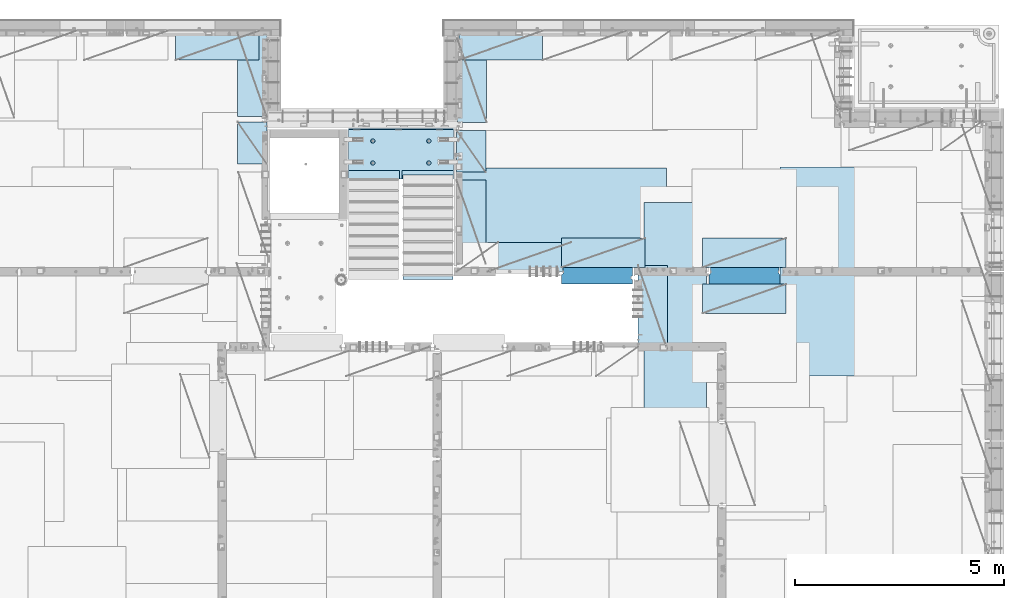
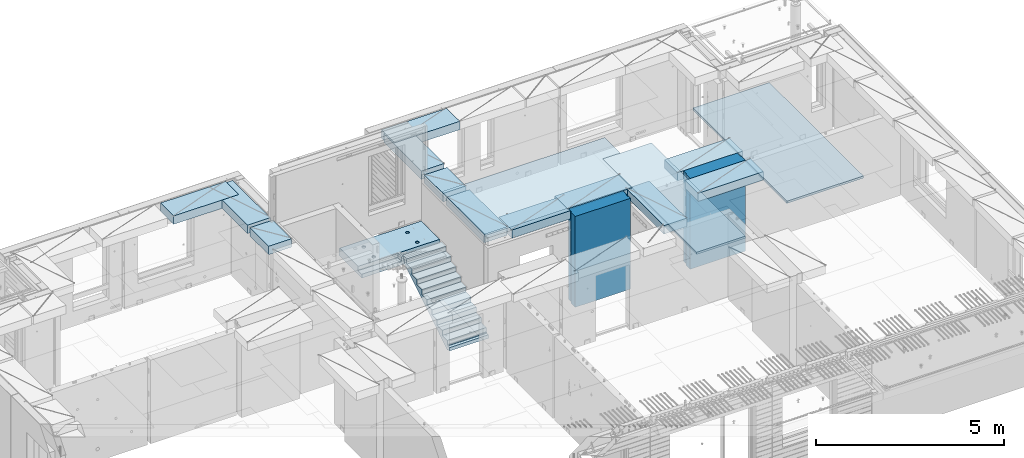
# One storey, part 201 of 341: 18 plates, 1 slab, 19 elements without a shape of their own.
"""IFC2X3 building model written with IfcOpenShell, lengths in millimetres."""

import ifcopenshell
import ifcopenshell.guid

model = None  # the IFC model being written
_history = None  # IfcOwnerHistory: only IFC2X3 demands one
_inside = {}  # id of a spatial element -> (the spatial element, [elements in it])
_under = {}  # id of a project, library or spatial element -> (it, [spatial elements below it])
_declared = {}  # id of a project -> (the project, [libraries it declares])
_typed = {}  # id of a type object -> (the type object, [elements of that type])
_made_of = {}  # id of a material, layer set ... -> (it, [elements and type objects made of it])


def new_model(schema):
    """Start an empty IFC model of exactly this schema.

    Asked for "IFC4X3", IfcOpenShell would pick the latest addendum, in which some entities
    have other attributes; the version numbers below select the first issue.
    IFC2X3 requires an IfcOwnerHistory on every rooted entity: one is made here for all.
    """
    global model, _history
    if schema == "IFC4X3":
        model = ifcopenshell.file(schema_version=(4, 3, 0, 0))
    else:
        model = ifcopenshell.file(schema=schema)
    _inside.clear()
    _under.clear()
    _declared.clear()
    _typed.clear()
    _made_of.clear()
    _history = None
    if model.schema == "IFC2X3":
        org = make("IfcOrganization", Name="unknown")
        user = make(
            "IfcPersonAndOrganization",
            ThePerson=make("IfcPerson", FamilyName="unknown"),
            TheOrganization=org,
        )
        app = make(
            "IfcApplication",
            ApplicationDeveloper=org,
            Version="unknown",
            ApplicationFullName="unknown",
            ApplicationIdentifier="unknown",
        )
        _history = make(
            "IfcOwnerHistory",
            OwningUser=user,
            OwningApplication=app,
            ChangeAction="ADDED",
            CreationDate=0,
        )
    return model


def make(cls, **values):
    """One entity of the class cls with the attributes given. An attribute that is None is left unset."""
    return model.create_entity(
        cls, **{name: value for name, value in values.items() if value is not None}
    )


def rooted(cls, **values):
    """An entity with a GlobalId (a new one), such as an element, a storey or a relation."""
    return make(cls, GlobalId=ifcopenshell.guid.new(), OwnerHistory=_history, **values)


def si_unit(unit_type, name, prefix=None):
    """IfcSIUnit, for example si_unit("LENGTHUNIT", "METRE", prefix="MILLI")."""
    return make("IfcSIUnit", UnitType=unit_type, Prefix=prefix, Name=name)


def assignment(units):
    """IfcUnitAssignment: the units of a project."""
    return None if units is None else make("IfcUnitAssignment", Units=units)


def point(xyz):
    """IfcCartesianPoint."""
    return None if xyz is None else make("IfcCartesianPoint", Coordinates=xyz)


def direction(xyz):
    """IfcDirection."""
    return None if xyz is None else make("IfcDirection", DirectionRatios=xyz)


def frame(location, z_axis=None, x_axis=None):
    """IfcAxis2Placement3D, a coordinate frame: its origin and axes. An axis left out is left unset."""
    return make(
        "IfcAxis2Placement3D",
        Location=point(location),
        Axis=direction(z_axis),
        RefDirection=direction(x_axis),
    )


def origin_with_axes():
    """The frame at (0, 0, 0) with the z axis (0, 0, 1) and the x axis (1, 0, 0) written out."""
    return frame((0.0, 0.0, 0.0), z_axis=(0.0, 0.0, 1.0), x_axis=(1.0, 0.0, 0.0))


def place(relative_to, where):
    """IfcLocalPlacement: puts the frame where relative to a parent placement (None: the world)."""
    return make(
        "IfcLocalPlacement", PlacementRelTo=relative_to, RelativePlacement=where
    )


def context(
    kind, dimensions, precision=None, world=None, true_north=None, identifier=None
):
    """IfcGeometricRepresentationContext, for example the 3D "Model" context."""
    return make(
        "IfcGeometricRepresentationContext",
        ContextIdentifier=identifier,
        ContextType=kind,
        CoordinateSpaceDimension=dimensions,
        Precision=precision,
        WorldCoordinateSystem=world,
        TrueNorth=true_north,
    )


def subcontext(parent, identifier, kind, view, scale=None):
    """IfcGeometricRepresentationSubContext, for example "Body" below "Model"."""
    return make(
        "IfcGeometricRepresentationSubContext",
        ContextIdentifier=identifier,
        ContextType=kind,
        ParentContext=parent,
        TargetScale=scale,
        TargetView=view,
    )


def project(units=None, contexts=None):
    """IfcProject with its units and contexts."""
    return rooted(
        "IfcProject",
        Name="project",
        RepresentationContexts=contexts,
        UnitsInContext=assignment(units),
    )


def spatial(cls, under=None, at=None, **own):
    """A site, building, storey or space (cls), placed at a placement, below another one or the project."""
    s = rooted(cls, ObjectPlacement=at, **own)
    if under is not None:
        _under.setdefault(under.id(), (under, []))[1].append(s)
    return s


def faces_of(points, faces, orient=None, outer=None):
    """IfcFace entities. A face is a list of loops; a loop is a list of indices into points, from 0.

    orient and outer hold one flag for each loop. By default every Orientation is true, the
    first loop of a face is its IfcFaceOuterBound and the others are IfcFaceBound.
    """
    made = []
    for i, loops in enumerate(faces):
        bounds = []
        for j, loop in enumerate(loops):
            is_outer = j == 0 if outer is None else outer[i][j]
            bounds.append(
                make(
                    "IfcFaceOuterBound" if is_outer else "IfcFaceBound",
                    Bound=make("IfcPolyLoop", Polygon=[points[k] for k in loop]),
                    Orientation=True if orient is None else orient[i][j],
                )
            )
        made.append(make("IfcFace", Bounds=bounds))
    return made


def faceted_brep(points, faces, orient=None, outer=None, voids=None):
    """IfcFacetedBrep: a solid bounded by flat faces; with voids (closed shells), ...WithVoids."""
    shared = [point(p) for p in points]
    hull = make("IfcClosedShell", CfsFaces=faces_of(shared, faces, orient, outer))
    if voids is None:
        return make("IfcFacetedBrep", Outer=hull)
    return make(
        "IfcFacetedBrepWithVoids",
        Outer=hull,
        Voids=[
            make(cls, CfsFaces=faces_of(shared, fs, o, b)) for cls, fs, o, b in voids
        ],
    )


def shape(context_of_items, identifier, shape_type, items):
    """IfcShapeRepresentation: the items that make up one representation, for example the "Body"."""
    return make(
        "IfcShapeRepresentation",
        ContextOfItems=context_of_items,
        RepresentationIdentifier=identifier,
        RepresentationType=shape_type,
        Items=items,
    )


def material(Name=None, Category=None):
    """IfcMaterial."""
    return make("IfcMaterial", Name=Name, Category=Category)


def made_of(thing, what):
    """Note that an element or type object is made of a material, layer set ...; save() writes the relation."""
    if what is not None:
        _made_of.setdefault(what.id(), (what, []))[1].append(thing)
    return thing


def type_object(cls, material=None, **own):
    """A type object (cls), such as IfcWallType, which elements share."""
    return made_of(rooted(cls, **own), material)


def element(
    cls,
    number,
    at=None,
    inside=None,
    cuts=None,
    type_object=None,
    material=None,
    context=None,
    identifier="Body",
    shape_type=None,
    held_by="IfcProductDefinitionShape",
    body=None,
    shapes=None,
    **own,
):
    """One element of the class cls, such as IfcWall. Its Tag is "e" and its number.

    at: its placement. inside: the storey or other place that contains it. cuts: it is an
    opening in that element (IfcRelVoidsElement). A single representation is given by context,
    identifier, shape_type and body (its items); several are given by shapes. held_by: the class
    of the entity that holds the representations. save() writes the other relations.
    """
    e = rooted(cls, Tag="e%d" % number, ObjectPlacement=at, **own)
    if body is not None:
        shapes = [shape(context, identifier, shape_type, body)]
    if shapes is not None:
        e.Representation = make(held_by, Representations=shapes)
    if inside is not None:
        _inside.setdefault(inside.id(), (inside, []))[1].append(e)
    if cuts is not None:
        rooted(
            "IfcRelVoidsElement", RelatingBuildingElement=cuts, RelatedOpeningElement=e
        )
    if type_object is not None:
        _typed.setdefault(type_object.id(), (type_object, []))[1].append(e)
    return made_of(e, material)


def aggregate(whole, parts):
    """IfcRelAggregates: a whole, such as a stair, and the parts it consists of."""
    return rooted("IfcRelAggregates", RelatingObject=whole, RelatedObjects=parts)


def save(model, path):
    """Write the relations noted so far, then the file.

    IfcRelAggregates (storeys below a building ...), IfcRelContainedInSpatialStructure (elements
    in a storey), IfcRelDefinesByType, IfcRelAssociatesMaterial and IfcRelDeclares: one each for
    every whole, place, type object, material and project.
    """
    for whole, parts in _under.values():
        aggregate(whole, parts)
    for where, things in _inside.values():
        rooted(
            "IfcRelContainedInSpatialStructure",
            RelatedElements=things,
            RelatingStructure=where,
        )
    for kind, things in _typed.values():
        rooted("IfcRelDefinesByType", RelatedObjects=things, RelatingType=kind)
    for what, things in _made_of.values():
        rooted("IfcRelAssociatesMaterial", RelatedObjects=things, RelatingMaterial=what)
    for by, libraries in _declared.values():
        rooted("IfcRelDeclares", RelatingContext=by, RelatedDefinitions=libraries)
    model.write(path)


model = new_model("IFC2X3")

# Units and contexts
model_context = context("Model", 3, precision=1e-05, world=origin_with_axes())
body_context = subcontext(model_context, "Body", "Model", "MODEL_VIEW")
ifc_project = project(units=[si_unit("LENGTHUNIT", "METRE", prefix="MILLI"), si_unit("AREAUNIT", "SQUARE_METRE"), si_unit("VOLUMEUNIT", "CUBIC_METRE"), si_unit("MASSUNIT", "GRAM", prefix="KILO"), si_unit("TIMEUNIT", "SECOND"), si_unit("PLANEANGLEUNIT", "RADIAN"), si_unit("SOLIDANGLEUNIT", "STERADIAN"), si_unit("THERMODYNAMICTEMPERATUREUNIT", "DEGREE_CELSIUS"), si_unit("LUMINOUSINTENSITYUNIT", "LUMEN")], contexts=[model_context])

# Site, building, storey
site_placement = place(None, origin_with_axes())
site = spatial("IfcSite", under=ifc_project, at=site_placement, CompositionType="ELEMENT")
building_placement = place(site_placement, origin_with_axes())
building = spatial("IfcBuilding", under=site, at=building_placement, CompositionType="ELEMENT")
storey_placement = place(building_placement, origin_with_axes())
storey = spatial("IfcBuildingStorey", under=building, at=storey_placement, Name="5", CompositionType="ELEMENT", Elevation=0.0)

# Assembly, plate
assembly_1_placement = place(storey_placement, origin_with_axes())
assembly_1 = element("IfcElementAssembly", 1, at=assembly_1_placement, inside=storey, Name="E9", AssemblyPlace="NOTDEFINED", PredefinedType="NOTDEFINED")
ifc_material_1 = material(Name="Undefined/C32/40")
plate_type_1 = type_object("IfcPlateType", PredefinedType="NOTDEFINED")
plate_1_placement = place(assembly_1_placement, frame((21585.002175553, 16880.001025346, 93759.7036072969), z_axis=(0.0, 1.0, 0.0), x_axis=(0.0, 0.0, -1.0)))
plate_1 = element("IfcPlate", 2, at=plate_1_placement, type_object=plate_type_1, material=ifc_material_1, Name="E9", context=body_context, shape_type="Brep", body=[
    faceted_brep([(0.0, -600.0, 0.0), (0.0, -600.0, 30.0), (0.0, 600.0, 30.0), (0.0, 600.0, 0.0), (-136.699996948242, -600.0, 30.0), (-136.699996948242, 600.0, 30.0), (-136.699996948242, -600.0, 300.0), (-136.699996948242, 600.0, 300.0), (-303.399993896484, -600.0, 300.0), (-303.399993896484, 600.0, 300.0), (-303.399993896484, -600.0, 570.0), (-303.399993896484, 600.0, 570.0), (-470.100006103516, -600.0, 570.0), (-470.100006103516, 600.0, 570.0), (-470.100006103516, -600.0, 840.0), (-470.100006103516, 600.0, 840.0), (-636.799987792969, -600.0, 840.0), (-636.799987792969, 600.0, 840.0), (-636.799987792969, -600.0, 1110.0), (-636.799987792969, 600.0, 1110.0), (-803.5, -600.0, 1110.0), (-803.5, 600.0, 1110.0), (-803.5, -600.0, 1380.0), (-803.5, 600.0, 1380.0), (-970.200012207031, -600.0, 1380.0), (-970.200012207031, 600.0, 1380.0), (-970.200012207031, -600.0, 1650.0), (-970.200012207031, 600.0, 1650.0), (-1136.90002441406, -600.0, 1650.0), (-1136.90002441406, 600.0, 1650.0), (-1136.90002441406, -600.0, 1920.0), (-1136.90002441406, 600.0, 1920.0), (-1303.59997558594, -600.0, 1920.0), (-1303.59997558594, 600.0, 1920.0), (-1303.59997558594, -600.0, 2190.0), (-1303.59997558594, 600.0, 2190.0), (-1470.30004882813, -600.0, 2190.0), (-1470.30004882813, 600.0, 2190.0), (-1470.30004882813, -600.0, 2410.0), (-1470.30004882813, 600.0, 2410.0), (-1370.30004882813, -600.0, 2410.0), (-1370.30004882813, 600.0, 2410.0), (-1370.30004882813, -600.0, 2310.0), (-1370.30004882813, 600.0, 2310.0), (-1236.65991210938, -600.0, 2310.0), (-1236.65991210938, 600.0, 2310.0), (170.0, -600.0, 31.6665592193604), (170.0, 600.0, 31.6665592193604), (170.0, -600.0, 20.0), (170.0, 600.0, 20.0), (135.0, -600.0, 20.0), (135.0, 600.0, 20.0), (135.0, -600.0, -90.0), (135.0, 600.0, -90.0), (25.0, -600.0, -90.0), (25.0, 600.0, -90.0), (25.0, -600.0, 0.0), (25.0, 600.0, 0.0)], [[[0, 1, 2, 3]], [[1, 4, 5, 2]], [[4, 6, 7, 5]], [[6, 8, 9, 7]], [[8, 10, 11, 9]], [[10, 12, 13, 11]], [[12, 14, 15, 13]], [[14, 16, 17, 15]], [[16, 18, 19, 17]], [[18, 20, 21, 19]], [[20, 22, 23, 21]], [[22, 24, 25, 23]], [[24, 26, 27, 25]], [[26, 28, 29, 27]], [[28, 30, 31, 29]], [[30, 32, 33, 31]], [[32, 34, 35, 33]], [[34, 36, 37, 35]], [[36, 38, 39, 37]], [[38, 40, 41, 39]], [[40, 42, 43, 41]], [[42, 44, 45, 43]], [[44, 46, 47, 45]], [[46, 48, 49, 47]], [[48, 50, 51, 49]], [[50, 52, 53, 51]], [[52, 54, 55, 53]], [[54, 56, 57, 55]], [[56, 0, 3, 57]], [[5, 7, 9, 11, 13, 15, 17, 19, 21, 23, 25, 27, 29, 31, 33, 35, 37, 39, 41, 43, 45, 47, 49, 51, 53, 55, 57, 3, 2]], [[56, 54, 52, 50, 48, 46, 44, 42, 40, 38, 36, 34, 32, 30, 28, 26, 24, 22, 20, 18, 16, 14, 12, 10, 8, 6, 4, 1, 0]]]),
])
aggregate(assembly_1, [plate_1])

# Assembly, slab
assembly_2_placement = place(storey_placement, origin_with_axes())
assembly_2 = element("IfcElementAssembly", 3, at=assembly_2_placement, inside=storey, AssemblyPlace="NOTDEFINED", PredefinedType="REINFORCEMENT_UNIT")
ifc_material_2 = material(Name="CONCRETE/C25/30")
slab_type = type_object("IfcSlabType", PredefinedType="NOTDEFINED")
slab_placement = place(assembly_2_placement, frame((19680.000385927, 19200.0003517906, 95120.0), z_axis=(0.0, 1.0, 0.0), x_axis=(1.0, 0.0, 0.0)))
slab = element("IfcSlab", 4, at=slab_placement, type_object=slab_type, material=ifc_material_2, PredefinedType="FLOOR", context=body_context, shape_type="Brep", body=[
    faceted_brep([(1284.99890682963, -130.0, 0.0), (1284.99890682963, 10.0003972196719, 0.0), (1284.99890682963, 10.0003972196719, 200.003967285156), (1284.99890682963, -130.0, 200.003967285156), (2510.00073788432, 10.0003972196719, 200.003967285156), (2509.998046875, 10.0003972196719, 0.0), (2510.00073788432, -130.0, 200.003967285156), (2509.998046875, 60.0, 1210.00146484375), (0.0, 60.0, 1210.00146484375), (0.0, 50.0000001803419, 1180.00146538467), (2509.998046875, 50.0000001803419, 1180.00146538467), (2509.998046875, 130.0, 1210.00146484375), (0.0, 130.0, 1210.00146484375), (2509.998046875, 130.0, 0.0), (0.0, 130.0, -1.81898940354586e-12), (1225.00073788432, 10.0003972196719, 0.0), (1225.00073788432, 10.0003972196719, 200.003967285156), (-0.00109317036549328, 10.0003972196719, 200.003967285156), (0.0, 10.0003972196719, 0.0), (1225.00073788432, -130.0, 200.003967285156), (1225.00073788432, -130.0, 0.0), (0.0, -130.0, 200.003967285156), (0.0, -130.0, 1180.00146417833), (2509.998046875, -130.0, 1180.00146417833), (1940.44809334572, -110.0, 331.258272818675), (1954.3865062416, -110.0, 338.360248914683), (1965.44809334572, -110.0, 349.42183601881), (1972.55006944173, -110.0, 363.360248914683), (1974.99724362697, -110.0, 378.811098633432), (1972.55006944173, -110.0, 394.261948352181), (1965.44809334572, -110.0, 408.200361248055), (1954.3865062416, -110.0, 419.261948352181), (1940.44809334572, -110.0, 426.363924448189), (1924.99724362697, -110.0, 428.811098633432), (1909.54639390823, -110.0, 426.363924448189), (1895.60798101235, -110.0, 419.261948352181), (1884.54639390823, -110.0, 408.200361248055), (1877.44441781222, -110.0, 394.261948352181), (1874.99724362697, -110.0, 378.811098633432), (1877.44441781222, -110.0, 363.360248914683), (1884.54639390823, -110.0, 349.42183601881), (1895.60798101235, -110.0, 338.360248914683), (1909.54639390823, -110.0, 331.258272818675), (1924.99724362697, -110.0, 328.811098633432), (1974.71156152422, -130.0, 394.964259703032), (1977.2699708997, -130.0, 378.811098633432), (1967.28676833294, -130.0, 409.536236821448), (1955.72238181499, -130.0, 421.100623339393), (1941.15040469657, -130.0, 428.52541653068), (1924.99724362697, -130.0, 431.08382590616), (1908.84408255737, -130.0, 428.52541653068), (1894.27210543896, -130.0, 421.100623339393), (1882.70771892101, -130.0, 409.536236821448), (1875.28292572973, -130.0, 394.964259703032), (1872.72451635425, -130.0, 378.811098633432), (1875.28292572973, -130.0, 362.657937563832), (1882.70771892101, -130.0, 348.085960445416), (1894.27210543896, -130.0, 336.521573927472), (1908.84408255737, -130.0, 329.096780736185), (1924.99724362697, -130.0, 326.538371360704), (1941.15040469657, -130.0, 329.096780736185), (1955.72238181499, -130.0, 336.521573927472), (1967.28676833294, -130.0, 348.085960445416), (1974.71156152422, -130.0, 362.657937563832), (1940.44809334572, -110.0, 858.458272818676), (1954.3865062416, -110.0, 865.560248914684), (1965.44809334572, -110.0, 876.62183601881), (1972.55006944173, -110.0, 890.560248914684), (1974.99724362697, -110.0, 906.011098633433), (1972.55006944173, -110.0, 921.461948352182), (1965.44809334572, -110.0, 935.400361248056), (1954.3865062416, -110.0, 946.461948352182), (1940.44809334572, -110.0, 953.56392444819), (1924.99724362697, -110.0, 956.011098633433), (1909.54639390823, -110.0, 953.56392444819), (1895.60798101235, -110.0, 946.461948352182), (1884.54639390823, -110.0, 935.400361248056), (1877.44441781222, -110.0, 921.461948352182), (1874.99724362697, -110.0, 906.011098633433), (1877.44441781222, -110.0, 890.560248914684), (1884.54639390823, -110.0, 876.62183601881), (1895.60798101235, -110.0, 865.560248914684), (1909.54639390823, -110.0, 858.458272818676), (1924.99724362697, -110.0, 856.011098633433), (1974.71156152422, -130.0, 922.164259703033), (1977.2699708997, -130.0, 906.011098633433), (1967.28676833294, -130.0, 936.736236821449), (1955.72238181499, -130.0, 948.300623339394), (1941.15040469657, -130.0, 955.72541653068), (1924.99724362697, -130.0, 958.283825906161), (1908.84408255737, -130.0, 955.72541653068), (1894.27210543896, -130.0, 948.300623339394), (1882.70771892101, -130.0, 936.736236821449), (1875.28292572973, -130.0, 922.164259703033), (1872.72451635425, -130.0, 906.011098633433), (1875.28292572973, -130.0, 889.857937563833), (1882.70771892101, -130.0, 875.285960445417), (1894.27210543896, -130.0, 863.721573927472), (1908.84408255737, -130.0, 856.296780736186), (1924.99724362697, -130.0, 853.738371360705), (1941.15040469657, -130.0, 856.296780736186), (1955.72238181499, -130.0, 863.721573927472), (1967.28676833294, -130.0, 875.285960445417), (1974.71156152422, -130.0, 889.857937563833), (569.611134800252, -110.0, 426.363924448189), (555.672721904379, -110.0, 419.261948352181), (544.611134800252, -110.0, 408.200361248055), (537.509158704244, -110.0, 394.261948352181), (535.061984519001, -110.0, 378.811098633432), (537.509158704244, -110.0, 363.360248914683), (544.611134800252, -110.0, 349.42183601881), (555.672721904379, -110.0, 338.360248914683), (569.611134800252, -110.0, 331.258272818675), (585.061984519001, -110.0, 328.811098633432), (600.51283423775, -110.0, 331.258272818675), (614.451247133624, -110.0, 338.360248914683), (625.51283423775, -110.0, 349.42183601881), (632.614810333758, -110.0, 363.360248914683), (635.061984519001, -110.0, 378.811098633432), (632.614810333758, -110.0, 394.261948352181), (625.51283423775, -110.0, 408.200361248055), (614.451247133624, -110.0, 419.261948352181), (600.51283423775, -110.0, 426.363924448189), (585.061984519001, -110.0, 428.811098633432), (634.776302416249, -130.0, 394.964259703032), (637.334711791729, -130.0, 378.811098633432), (627.351509224962, -130.0, 409.536236821448), (615.787122707017, -130.0, 421.100623339393), (601.215145588601, -130.0, 428.52541653068), (585.061984519001, -130.0, 431.08382590616), (568.908823449401, -130.0, 428.52541653068), (554.336846330985, -130.0, 421.100623339393), (542.772459813041, -130.0, 409.536236821448), (535.347666621754, -130.0, 394.964259703032), (532.789257246273, -130.0, 378.811098633432), (535.347666621754, -130.0, 362.657937563832), (542.772459813041, -130.0, 348.085960445416), (554.336846330985, -130.0, 336.521573927472), (568.908823449401, -130.0, 329.096780736185), (585.061984519001, -130.0, 326.538371360704), (601.215145588601, -130.0, 329.096780736185), (615.787122707017, -130.0, 336.521573927472), (627.351509224962, -130.0, 348.085960445416), (634.776302416249, -130.0, 362.657937563832), (569.611134800252, -110.0, 953.56392444819), (555.672721904379, -110.0, 946.461948352182), (544.611134800252, -110.0, 935.400361248056), (537.509158704244, -110.0, 921.461948352182), (535.061984519001, -110.0, 906.011098633433), (537.509158704244, -110.0, 890.560248914684), (544.611134800252, -110.0, 876.62183601881), (555.672721904379, -110.0, 865.560248914684), (569.611134800252, -110.0, 858.458272818676), (585.061984519001, -110.0, 856.011098633433), (600.51283423775, -110.0, 858.458272818676), (614.451247133624, -110.0, 865.560248914684), (625.51283423775, -110.0, 876.62183601881), (632.614810333758, -110.0, 890.560248914684), (635.061984519001, -110.0, 906.011098633433), (632.614810333758, -110.0, 921.461948352182), (625.51283423775, -110.0, 935.400361248056), (614.451247133624, -110.0, 946.461948352182), (600.51283423775, -110.0, 953.56392444819), (585.061984519001, -110.0, 956.011098633433), (634.776302416249, -130.0, 922.164259703033), (637.334711791729, -130.0, 906.011098633433), (627.351509224962, -130.0, 936.736236821449), (615.787122707017, -130.0, 948.300623339394), (601.215145588601, -130.0, 955.72541653068), (585.061984519001, -130.0, 958.283825906161), (568.908823449401, -130.0, 955.72541653068), (554.336846330985, -130.0, 948.300623339394), (542.772459813041, -130.0, 936.736236821449), (535.347666621754, -130.0, 922.164259703033), (532.789257246273, -130.0, 906.011098633433), (535.347666621754, -130.0, 889.857937563833), (542.772459813041, -130.0, 875.285960445417), (554.336846330985, -130.0, 863.721573927472), (568.908823449401, -130.0, 856.296780736186), (585.061984519001, -130.0, 853.738371360705), (601.215145588601, -130.0, 856.296780736186), (615.787122707017, -130.0, 863.721573927472), (627.351509224962, -130.0, 875.285960445417), (634.776302416249, -130.0, 889.857937563833)], [[[0, 1, 2, 3]], [[4, 2, 1, 5]], [[6, 3, 2, 4]], [[7, 8, 9, 10]], [[11, 12, 8, 7]], [[11, 13, 14, 12]], [[15, 16, 17, 18]], [[19, 16, 15, 20]], [[21, 17, 16, 19]], [[22, 9, 8, 12, 14, 18, 17, 21]], [[23, 10, 9, 22]], [[5, 13, 11, 7, 10, 23, 6, 4]], [[0, 20, 15, 18, 14, 13, 5, 1]], [[24, 25, 26, 27, 28, 29, 30, 31, 32, 33, 34, 35, 36, 37, 38, 39, 40, 41, 42, 43]], [[44, 29, 28, 45]], [[46, 30, 29, 44]], [[47, 31, 30, 46]], [[48, 32, 31, 47]], [[49, 33, 32, 48]], [[50, 34, 33, 49]], [[51, 35, 34, 50]], [[52, 36, 35, 51]], [[53, 37, 36, 52]], [[54, 38, 37, 53]], [[55, 39, 38, 54]], [[56, 40, 39, 55]], [[57, 41, 40, 56]], [[58, 42, 41, 57]], [[59, 43, 42, 58]], [[60, 24, 43, 59]], [[61, 25, 24, 60]], [[62, 26, 25, 61]], [[63, 27, 26, 62]], [[45, 28, 27, 63]], [[64, 65, 66, 67, 68, 69, 70, 71, 72, 73, 74, 75, 76, 77, 78, 79, 80, 81, 82, 83]], [[84, 69, 68, 85]], [[86, 70, 69, 84]], [[87, 71, 70, 86]], [[88, 72, 71, 87]], [[89, 73, 72, 88]], [[90, 74, 73, 89]], [[91, 75, 74, 90]], [[92, 76, 75, 91]], [[93, 77, 76, 92]], [[94, 78, 77, 93]], [[95, 79, 78, 94]], [[96, 80, 79, 95]], [[97, 81, 80, 96]], [[98, 82, 81, 97]], [[99, 83, 82, 98]], [[100, 64, 83, 99]], [[101, 65, 64, 100]], [[102, 66, 65, 101]], [[103, 67, 66, 102]], [[85, 68, 67, 103]], [[104, 105, 106, 107, 108, 109, 110, 111, 112, 113, 114, 115, 116, 117, 118, 119, 120, 121, 122, 123]], [[124, 119, 118, 125]], [[126, 120, 119, 124]], [[127, 121, 120, 126]], [[128, 122, 121, 127]], [[129, 123, 122, 128]], [[130, 104, 123, 129]], [[131, 105, 104, 130]], [[132, 106, 105, 131]], [[133, 107, 106, 132]], [[134, 108, 107, 133]], [[135, 109, 108, 134]], [[136, 110, 109, 135]], [[137, 111, 110, 136]], [[138, 112, 111, 137]], [[139, 113, 112, 138]], [[140, 114, 113, 139]], [[141, 115, 114, 140]], [[142, 116, 115, 141]], [[143, 117, 116, 142]], [[125, 118, 117, 143]], [[144, 145, 146, 147, 148, 149, 150, 151, 152, 153, 154, 155, 156, 157, 158, 159, 160, 161, 162, 163]], [[164, 159, 158, 165]], [[166, 160, 159, 164]], [[167, 161, 160, 166]], [[168, 162, 161, 167]], [[169, 163, 162, 168]], [[170, 144, 163, 169]], [[171, 145, 144, 170]], [[172, 146, 145, 171]], [[173, 147, 146, 172]], [[174, 148, 147, 173]], [[175, 149, 148, 174]], [[176, 150, 149, 175]], [[177, 151, 150, 176]], [[178, 152, 151, 177]], [[179, 153, 152, 178]], [[180, 154, 153, 179]], [[181, 155, 154, 180]], [[182, 156, 155, 181]], [[183, 157, 156, 182]], [[165, 158, 157, 183]], [[23, 22, 21, 19, 20, 0, 3, 6], [182, 181, 180, 179, 178, 177, 176, 175, 174, 173, 172, 171, 170, 169, 168, 167, 166, 164, 165, 183], [142, 141, 140, 139, 138, 137, 136, 135, 134, 133, 132, 131, 130, 129, 128, 127, 126, 124, 125, 143], [102, 101, 100, 99, 98, 97, 96, 95, 94, 93, 92, 91, 90, 89, 88, 87, 86, 84, 85, 103], [62, 61, 60, 59, 58, 57, 56, 55, 54, 53, 52, 51, 50, 49, 48, 47, 46, 44, 45, 63]]]),
])
aggregate(assembly_2, [slab])

# Assembly, plate
assembly_3_placement = place(storey_placement, origin_with_axes())
assembly_3 = element("IfcElementAssembly", 5, at=assembly_3_placement, inside=storey, Name="Steel Assembly", AssemblyPlace="NOTDEFINED", PredefinedType="NOTDEFINED")
ifc_material_3 = material()
plate_type_2 = type_object("IfcPlateType", PredefinedType="NOTDEFINED")
plate_2_placement = place(assembly_3_placement, frame((22289.9998779297, 19460.0009765625, 96695.1), z_axis=(1.0, 0.0, 0.0), x_axis=(0.0, -1.0, 0.0)))
plate_2 = element("IfcPlate", 6, at=plate_2_placement, type_object=plate_type_2, material=ifc_material_3, context=body_context, shape_type="Brep", body=[
    faceted_brep([(0.0, -35.0, 0.0), (0.0, -35.0, 5000.0), (0.0, 35.0, 5000.0), (0.0, 35.0, 0.0), (2349.99951171875, -35.0, 5000.0), (2349.99951171875, 35.0, 5000.0), (2350.0, -35.0, 0.0), (2350.0, 35.0, 0.0)], [[[0, 1, 2, 3]], [[1, 4, 5, 2]], [[4, 6, 7, 5]], [[6, 0, 3, 7]], [[5, 7, 3, 2]], [[6, 4, 1, 0]]]),
])
aggregate(assembly_3, [plate_2])

assembly_4_placement = place(storey_placement, origin_with_axes())
assembly_4 = element("IfcElementAssembly", 7, at=assembly_4_placement, inside=storey, Name="Steel Assembly", AssemblyPlace="NOTDEFINED", PredefinedType="NOTDEFINED")
plate_3_placement = place(assembly_4_placement, frame((32360.0, 19480.0, 96695.1), z_axis=(0.0, -1.0, 0.0), x_axis=(-1.0, 3.00000001838171e-08, 0.0)))
plate_3 = element("IfcPlate", 8, at=plate_3_placement, type_object=plate_type_2, material=ifc_material_3, context=body_context, shape_type="Brep", body=[
    faceted_brep([(0.0, -35.0, 0.0), (0.0, -35.0, 5000.0), (0.0, 35.0, 5000.0), (0.0, 35.0, 0.0), (2349.99951171875, -35.0, 5000.0), (2349.99951171875, 35.0, 5000.0), (2350.0, -35.0, 0.0), (2350.0, 35.0, 0.0)], [[[0, 1, 2, 3]], [[1, 4, 5, 2]], [[4, 6, 7, 5]], [[6, 0, 3, 7]], [[5, 7, 3, 2]], [[6, 4, 1, 0]]]),
])
aggregate(assembly_4, [plate_3])

assembly_5_placement = place(storey_placement, origin_with_axes())
assembly_5 = element("IfcElementAssembly", 9, at=assembly_5_placement, inside=storey, Name="Steel Assembly", AssemblyPlace="NOTDEFINED", PredefinedType="NOTDEFINED")
plate_type_3 = type_object("IfcPlateType", PredefinedType="NOTDEFINED")
plate_4_placement = place(assembly_5_placement, frame((28250.0000122641, 18630.0, 96695.1000003815), z_axis=(0.0, -1.0, 0.0), x_axis=(-1.0, 3.00000001838171e-08, 0.0)))
plate_4 = element("IfcPlate", 10, at=plate_4_placement, type_object=plate_type_3, material=ifc_material_3, context=body_context, shape_type="Brep", body=[
    faceted_brep([(0.0, -35.0, 0.0), (0.0, -35.0, 5000.0), (0.0, 35.0, 5000.0), (0.0, 35.0, 0.0), (1499.99951171875, -35.0, 5000.0), (1499.99951171875, 35.0, 5000.0), (1500.0, -35.0, 0.0), (1500.0, 35.0, 0.0)], [[[0, 1, 2, 3]], [[1, 4, 5, 2]], [[4, 6, 7, 5]], [[6, 0, 3, 7]], [[5, 7, 3, 2]], [[6, 4, 1, 0]]]),
])
aggregate(assembly_5, [plate_4])

assembly_6_placement = place(storey_placement, origin_with_axes())
assembly_6 = element("IfcElementAssembly", 11, at=assembly_6_placement, inside=storey, Name="Steel Assembly", AssemblyPlace="NOTDEFINED", PredefinedType="NOTDEFINED")
plate_type_4 = type_object("IfcPlateType", PredefinedType="NOTDEFINED")
plate_5_placement = place(assembly_6_placement, frame((24330.0, 22740.0001220703, 96595.3), z_axis=(0.0, -1.0, 0.0), x_axis=(-1.0, 3.00000001838171e-08, 0.0)))
plate_5 = element("IfcPlate", 12, at=plate_5_placement, type_object=plate_type_4, material=ifc_material_3, Name="RE1", context=body_context, shape_type="Brep", body=[
    faceted_brep([(1.81898940354586e-12, -135.0, 1.81898940354586e-12), (0.0, -135.0, 699.999999999996), (0.0, 135.0, 699.999999999996), (1.81898940354586e-12, 135.0, 1.81898940354586e-12), (1999.99951171875, -135.0, 699.999999999993), (1999.99951171875, 135.0, 699.999999999993), (2000.0, -135.0, -3.63797880709171e-12), (2000.0, 135.0, -3.63797880709171e-12)], [[[0, 1, 2, 3]], [[1, 4, 5, 2]], [[4, 6, 7, 5]], [[6, 0, 3, 7]], [[5, 7, 3, 2]], [[6, 4, 1, 0]]]),
])
aggregate(assembly_6, [plate_5])

assembly_7_placement = place(storey_placement, origin_with_axes())
assembly_7 = element("IfcElementAssembly", 13, at=assembly_7_placement, inside=storey, Name="Steel Assembly", AssemblyPlace="NOTDEFINED", PredefinedType="NOTDEFINED")
plate_6_placement = place(assembly_7_placement, frame((17730.0001220703, 20690.0, 96595.3), z_axis=(-1.0, 3.00000001838171e-08, 0.0), x_axis=(0.0, 1.0, 0.0)))
plate_6 = element("IfcPlate", 14, at=plate_6_placement, type_object=plate_type_4, material=ifc_material_3, Name="RE1", context=body_context, shape_type="Brep", body=[
    faceted_brep([(1.81898940354586e-12, -135.0, 1.81898940354586e-12), (0.0, -135.0, 699.999999999996), (0.0, 135.0, 699.999999999996), (1.81898940354586e-12, 135.0, 1.81898940354586e-12), (1999.99951171875, -135.0, 699.999999999993), (1999.99951171875, 135.0, 699.999999999993), (2000.0, -135.0, -3.63797880709171e-12), (2000.0, 135.0, -3.63797880709171e-12)], [[[0, 1, 2, 3]], [[1, 4, 5, 2]], [[4, 6, 7, 5]], [[6, 0, 3, 7]], [[5, 7, 3, 2]], [[6, 4, 1, 0]]]),
])
aggregate(assembly_7, [plate_6])

assembly_8_placement = place(storey_placement, origin_with_axes())
assembly_8 = element("IfcElementAssembly", 15, at=assembly_8_placement, inside=storey, Name="Steel Assembly", AssemblyPlace="NOTDEFINED", PredefinedType="NOTDEFINED")
plate_7_placement = place(assembly_8_placement, frame((22269.9998779297, 19170.0, 96595.3), z_axis=(1.0, 0.0, 0.0), x_axis=(0.0, -1.0, 0.0)))
plate_7 = element("IfcPlate", 16, at=plate_7_placement, type_object=plate_type_4, material=ifc_material_3, Name="RE1", context=body_context, shape_type="Brep", body=[
    faceted_brep([(1.81898940354586e-12, -135.0, 1.81898940354586e-12), (0.0, -135.0, 699.999999999996), (0.0, 135.0, 699.999999999996), (1.81898940354586e-12, 135.0, 1.81898940354586e-12), (1999.99951171875, -135.0, 699.999999999993), (1999.99951171875, 135.0, 699.999999999993), (2000.0, -135.0, -3.63797880709171e-12), (2000.0, 135.0, -3.63797880709171e-12)], [[[0, 1, 2, 3]], [[1, 4, 5, 2]], [[4, 6, 7, 5]], [[6, 0, 3, 7]], [[5, 7, 3, 2]], [[6, 4, 1, 0]]]),
])
aggregate(assembly_8, [plate_7])

assembly_9_placement = place(storey_placement, origin_with_axes())
assembly_9 = element("IfcElementAssembly", 17, at=assembly_9_placement, inside=storey, Name="Steel Assembly", AssemblyPlace="NOTDEFINED", PredefinedType="NOTDEFINED")
plate_8_placement = place(assembly_9_placement, frame((22289.9998779297, 22550.0, 96595.3), z_axis=(1.0, 0.0, 0.0), x_axis=(0.0, -1.0, 0.0)))
plate_8 = element("IfcPlate", 18, at=plate_8_placement, type_object=plate_type_4, material=ifc_material_3, Name="RE1", context=body_context, shape_type="Brep", body=[
    faceted_brep([(1.81898940354586e-12, -135.0, 1.81898940354586e-12), (0.0, -135.0, 699.999999999996), (0.0, 135.0, 699.999999999996), (1.81898940354586e-12, 135.0, 1.81898940354586e-12), (1999.99951171875, -135.0, 699.999999999993), (1999.99951171875, 135.0, 699.999999999993), (2000.0, -135.0, -3.63797880709171e-12), (2000.0, 135.0, -3.63797880709171e-12)], [[[0, 1, 2, 3]], [[1, 4, 5, 2]], [[4, 6, 7, 5]], [[6, 0, 3, 7]], [[5, 7, 3, 2]], [[6, 4, 1, 0]]]),
])
aggregate(assembly_9, [plate_8])

assembly_10_placement = place(storey_placement, origin_with_axes())
assembly_10 = element("IfcElementAssembly", 19, at=assembly_10_placement, inside=storey, Name="Steel Assembly", AssemblyPlace="NOTDEFINED", PredefinedType="NOTDEFINED")
plate_9_placement = place(assembly_10_placement, frame((22269.9999999293, 20360.0, 96595.3), z_axis=(1.0, 0.0, 0.0), x_axis=(0.0, -1.0, 0.0)))
plate_9 = element("IfcPlate", 20, at=plate_9_placement, type_object=plate_type_4, material=ifc_material_3, Name="RE1_1/2", context=body_context, shape_type="Brep", body=[
    faceted_brep([(1.81898940354586e-12, -135.0, 1.81898940354586e-12), (0.0, -135.0, 699.999999999996), (0.0, 135.0, 699.999999999996), (1.81898940354586e-12, 135.0, 1.81898940354586e-12), (999.99951171875, -135.0, 700.0), (999.99951171875, 135.0, 700.0), (1000.0, -135.0, 0.0), (1000.0, 135.0, 0.0)], [[[0, 1, 2, 3]], [[1, 4, 5, 2]], [[4, 6, 7, 5]], [[6, 0, 3, 7]], [[5, 7, 3, 2]], [[6, 4, 1, 0]]]),
])
aggregate(assembly_10, [plate_9])

assembly_11_placement = place(storey_placement, origin_with_axes())
assembly_11 = element("IfcElementAssembly", 21, at=assembly_11_placement, inside=storey, Name="Steel Assembly", AssemblyPlace="NOTDEFINED", PredefinedType="NOTDEFINED")
plate_10_placement = place(assembly_11_placement, frame((23010.0008542386, 16980.0001036336, 96595.3), z_axis=(0.0, 1.0, 0.0), x_axis=(1.0, 0.0, 0.0)))
plate_10 = element("IfcPlate", 22, at=plate_10_placement, type_object=plate_type_4, material=ifc_material_3, Name="RE1", context=body_context, shape_type="Brep", body=[
    faceted_brep([(1.81898940354586e-12, -135.0, 1.81898940354586e-12), (0.0, -135.0, 699.999999999996), (0.0, 135.0, 699.999999999996), (1.81898940354586e-12, 135.0, 1.81898940354586e-12), (1999.99951171875, -135.0, 699.999999999993), (1999.99951171875, 135.0, 699.999999999993), (2000.0, -135.0, -3.63797880709171e-12), (2000.0, 135.0, -3.63797880709171e-12)], [[[0, 1, 2, 3]], [[1, 4, 5, 2]], [[4, 6, 7, 5]], [[6, 0, 3, 7]], [[5, 7, 3, 2]], [[6, 4, 1, 0]]]),
])
aggregate(assembly_11, [plate_10])

assembly_12_placement = place(storey_placement, origin_with_axes())
assembly_12 = element("IfcElementAssembly", 23, at=assembly_12_placement, inside=storey, Name="Steel Assembly", AssemblyPlace="NOTDEFINED", PredefinedType="NOTDEFINED")
plate_11_placement = place(assembly_12_placement, frame((30152.4991457614, 16679.9998963664, 96595.3), z_axis=(0.0, -1.0, 0.0), x_axis=(-1.0, 3.00000001838171e-08, 0.0)))
plate_11 = element("IfcPlate", 24, at=plate_11_placement, type_object=plate_type_4, material=ifc_material_3, Name="RE1", context=body_context, shape_type="Brep", body=[
    faceted_brep([(1.81898940354586e-12, -135.0, 1.81898940354586e-12), (0.0, -135.0, 699.999999999996), (0.0, 135.0, 699.999999999996), (1.81898940354586e-12, 135.0, 1.81898940354586e-12), (1999.99951171875, -135.0, 699.999999999993), (1999.99951171875, 135.0, 699.999999999993), (2000.0, -135.0, -3.63797880709171e-12), (2000.0, 135.0, -3.63797880709171e-12)], [[[0, 1, 2, 3]], [[1, 4, 5, 2]], [[4, 6, 7, 5]], [[6, 0, 3, 7]], [[5, 7, 3, 2]], [[6, 4, 1, 0]]]),
])
aggregate(assembly_12, [plate_11])

assembly_13_placement = place(storey_placement, origin_with_axes())
assembly_13 = element("IfcElementAssembly", 25, at=assembly_13_placement, inside=storey, Name="Steel Assembly", AssemblyPlace="NOTDEFINED", PredefinedType="NOTDEFINED")
plate_12_placement = place(assembly_13_placement, frame((28152.5008542386, 17080.0001036336, 96595.3), z_axis=(0.0, 1.0, 0.0), x_axis=(1.0, 0.0, 0.0)))
plate_12 = element("IfcPlate", 26, at=plate_12_placement, type_object=plate_type_4, material=ifc_material_3, Name="RE1", context=body_context, shape_type="Brep", body=[
    faceted_brep([(1.81898940354586e-12, -135.0, 1.81898940354586e-12), (0.0, -135.0, 699.999999999996), (0.0, 135.0, 699.999999999996), (1.81898940354586e-12, 135.0, 1.81898940354586e-12), (1999.99951171875, -135.0, 699.999999999993), (1999.99951171875, 135.0, 699.999999999993), (2000.0, -135.0, -3.63797880709171e-12), (2000.0, 135.0, -3.63797880709171e-12)], [[[0, 1, 2, 3]], [[1, 4, 5, 2]], [[4, 6, 7, 5]], [[6, 0, 3, 7]], [[5, 7, 3, 2]], [[6, 4, 1, 0]]]),
])
aggregate(assembly_13, [plate_12])

assembly_14_placement = place(storey_placement, origin_with_axes())
assembly_14 = element("IfcElementAssembly", 27, at=assembly_14_placement, inside=storey, Name="Steel Assembly", AssemblyPlace="NOTDEFINED", PredefinedType="NOTDEFINED")
plate_13_placement = place(assembly_14_placement, frame((24780.0008542386, 17080.0001036336, 96595.3), z_axis=(0.0, 1.0, 0.0), x_axis=(1.0, 0.0, 0.0)))
plate_13 = element("IfcPlate", 28, at=plate_13_placement, type_object=plate_type_4, material=ifc_material_3, Name="RE1", context=body_context, shape_type="Brep", body=[
    faceted_brep([(1.81898940354586e-12, -135.0, 1.81898940354586e-12), (0.0, -135.0, 699.999999999996), (0.0, 135.0, 699.999999999996), (1.81898940354586e-12, 135.0, 1.81898940354586e-12), (1999.99951171875, -135.0, 699.999999999993), (1999.99951171875, 135.0, 699.999999999993), (2000.0, -135.0, -3.63797880709171e-12), (2000.0, 135.0, -3.63797880709171e-12)], [[[0, 1, 2, 3]], [[1, 4, 5, 2]], [[4, 6, 7, 5]], [[6, 0, 3, 7]], [[5, 7, 3, 2]], [[6, 4, 1, 0]]]),
])
aggregate(assembly_14, [plate_13])

assembly_15_placement = place(storey_placement, origin_with_axes())
assembly_15 = element("IfcElementAssembly", 29, at=assembly_15_placement, inside=storey, Name="Steel Assembly", AssemblyPlace="NOTDEFINED", PredefinedType="NOTDEFINED")
plate_14_placement = place(assembly_15_placement, frame((26609.9998779297, 17130.0, 96595.3), z_axis=(1.0, 0.0, 0.0), x_axis=(0.0, -1.0, 0.0)))
plate_14 = element("IfcPlate", 30, at=plate_14_placement, type_object=plate_type_4, material=ifc_material_3, Name="RE1", context=body_context, shape_type="Brep", body=[
    faceted_brep([(1.81898940354586e-12, -135.0, 1.81898940354586e-12), (0.0, -135.0, 699.999999999996), (0.0, 135.0, 699.999999999996), (1.81898940354586e-12, 135.0, 1.81898940354586e-12), (1999.99951171875, -135.0, 699.999999999993), (1999.99951171875, 135.0, 699.999999999993), (2000.0, -135.0, -3.63797880709171e-12), (2000.0, 135.0, -3.63797880709171e-12)], [[[0, 1, 2, 3]], [[1, 4, 5, 2]], [[4, 6, 7, 5]], [[6, 0, 3, 7]], [[5, 7, 3, 2]], [[6, 4, 1, 0]]]),
])
aggregate(assembly_15, [plate_14])

assembly_16_placement = place(storey_placement, origin_with_axes())
assembly_16 = element("IfcElementAssembly", 31, at=assembly_16_placement, inside=storey, Name="Steel Assembly", AssemblyPlace="NOTDEFINED", PredefinedType="NOTDEFINED")
plate_15_placement = place(assembly_16_placement, frame((17730.0000000707, 19560.0, 96595.3), z_axis=(-1.0, 3.00000001838171e-08, 0.0), x_axis=(0.0, 1.0, 0.0)))
plate_15 = element("IfcPlate", 32, at=plate_15_placement, type_object=plate_type_4, material=ifc_material_3, Name="RE1_1/2", context=body_context, shape_type="Brep", body=[
    faceted_brep([(1.81898940354586e-12, -135.0, 1.81898940354586e-12), (0.0, -135.0, 699.999999999996), (0.0, 135.0, 699.999999999996), (1.81898940354586e-12, 135.0, 1.81898940354586e-12), (999.99951171875, -135.0, 700.0), (999.99951171875, 135.0, 700.0), (1000.0, -135.0, 0.0), (1000.0, 135.0, 0.0)], [[[0, 1, 2, 3]], [[1, 4, 5, 2]], [[4, 6, 7, 5]], [[6, 0, 3, 7]], [[5, 7, 3, 2]], [[6, 4, 1, 0]]]),
])
aggregate(assembly_16, [plate_15])

assembly_17_placement = place(storey_placement, origin_with_axes())
assembly_17 = element("IfcElementAssembly", 33, at=assembly_17_placement, inside=storey, Name="Steel Assembly", AssemblyPlace="NOTDEFINED", PredefinedType="NOTDEFINED")
plate_16_placement = place(assembly_17_placement, frame((17545.0, 22740.0001220703, 96595.3), z_axis=(0.0, -1.0, 0.0), x_axis=(-1.0, 3.00000001838171e-08, 0.0)))
plate_16 = element("IfcPlate", 34, at=plate_16_placement, type_object=plate_type_4, material=ifc_material_3, Name="RE1", context=body_context, shape_type="Brep", body=[
    faceted_brep([(1.81898940354586e-12, -135.0, 1.81898940354586e-12), (0.0, -135.0, 699.999999999996), (0.0, 135.0, 699.999999999996), (1.81898940354586e-12, 135.0, 1.81898940354586e-12), (1999.99951171875, -135.0, 699.999999999993), (1999.99951171875, 135.0, 699.999999999993), (2000.0, -135.0, -3.63797880709171e-12), (2000.0, 135.0, -3.63797880709171e-12)], [[[0, 1, 2, 3]], [[1, 4, 5, 2]], [[4, 6, 7, 5]], [[6, 0, 3, 7]], [[5, 7, 3, 2]], [[6, 4, 1, 0]]]),
])
aggregate(assembly_17, [plate_16])

assembly_18_placement = place(storey_placement, origin_with_axes())
assembly_18 = element("IfcElementAssembly", 35, at=assembly_18_placement, inside=storey, Name="Steel Assembly", AssemblyPlace="NOTDEFINED", PredefinedType="NOTDEFINED")
ifc_material_4 = material()
plate_type_5 = type_object("IfcPlateType", PredefinedType="NOTDEFINED")
plate_17_placement = place(assembly_18_placement, frame((24780.0, 16680.0, 95255.6000003815), z_axis=(0.0, 1.0, 0.0), x_axis=(1.0, 0.0, 0.0)))
plate_17 = element("IfcPlate", 36, at=plate_17_placement, type_object=plate_type_5, material=ifc_material_4, context=body_context, shape_type="Brep", body=[
    faceted_brep([(1699.99914550781, -1475.0, 110.0), (1699.99914550781, 1475.0, 110.0), (1669.99914550781, 1475.0, 110.0), (1669.99914550781, -1475.00000000001, 110.0), (1669.99914550781, 1475.0, 200.0), (1669.99914550781, -1475.00000000001, 200.0), (1699.99914550781, -1475.0, 200.0), (1699.99914550781, 1475.0, 200.0), (1699.99914550781, -1475.0, 3.63797880709171e-12), (0.0, -1475.0, 0.0), (0.0, 1475.0, 0.0), (1699.99914550781, 1475.0, 3.63797880709171e-12), (0.0, -1475.0, 230.0), (0.0, 1475.0, 230.0), (30.0, -1475.0, 243.0), (30.0, 1475.0, 243.0), (30.0, -1475.0, 400.0), (30.0, 1475.0, 400.0), (1699.99914550781, -1475.0, 400.0), (1699.99914550781, 1475.0, 400.0)], [[[0, 1, 2, 3]], [[3, 2, 4, 5]], [[6, 5, 4, 7]], [[8, 9, 10, 11]], [[10, 9, 12, 13]], [[14, 15, 13, 12]], [[16, 17, 15, 14]], [[18, 19, 17, 16]], [[19, 18, 6, 7]], [[2, 1, 11, 10, 13, 15, 17, 19, 7, 4]], [[8, 11, 1, 0]], [[18, 16, 14, 12, 9, 8, 0, 3, 5, 6]]]),
])
aggregate(assembly_18, [plate_17])

assembly_19_placement = place(storey_placement, origin_with_axes())
assembly_19 = element("IfcElementAssembly", 37, at=assembly_19_placement, inside=storey, Name="Steel Assembly", AssemblyPlace="NOTDEFINED", PredefinedType="NOTDEFINED")
plate_18_placement = place(assembly_19_placement, frame((28309.9999105288, 16680.0000293051, 95255.6000003815), z_axis=(0.0, 1.0, 0.0), x_axis=(1.0, 0.0, 0.0)))
plate_18 = element("IfcPlate", 38, at=plate_18_placement, type_object=plate_type_5, material=ifc_material_4, context=body_context, shape_type="Brep", body=[
    faceted_brep([(29.9999989126591, -1475.0, 243.000885767418), (29.9999989126591, 1475.0, 243.000885767418), (0.0, 1475.0, 230.000886222213), (0.0, -1475.0, 230.000886222213), (30.0000025741901, -1475.0, 399.999635204884), (30.0000025741901, 1475.0, 399.999633789063), (1700.00073242188, -1475.0, 0.0), (0.0, -1475.0, 0.0), (0.0, 1475.0, 0.0), (1700.00073242188, 1475.0, 0.0), (1700.00073242188, 1475.0, 230.001129150391), (1700.00041094652, -1475.0, 230.001129150391), (1670.00041094652, 1475.0, 243.001129150391), (1670.00041094652, -1475.0, 243.001129150391), (1670.00041094652, -1475.0, 399.999633789063), (1670.00041094652, 1475.0, 399.999633789063)], [[[0, 1, 2, 3]], [[4, 5, 1, 0]], [[6, 7, 8, 9]], [[6, 9, 10, 11]], [[11, 10, 12, 13]], [[14, 13, 12, 15]], [[3, 7, 6, 11, 13, 14, 4, 0]], [[8, 7, 3, 2]], [[15, 12, 10, 9, 8, 2, 1, 5]], [[14, 15, 5, 4]]]),
])
aggregate(assembly_19, [plate_18])

save(model, "model.ifc")
